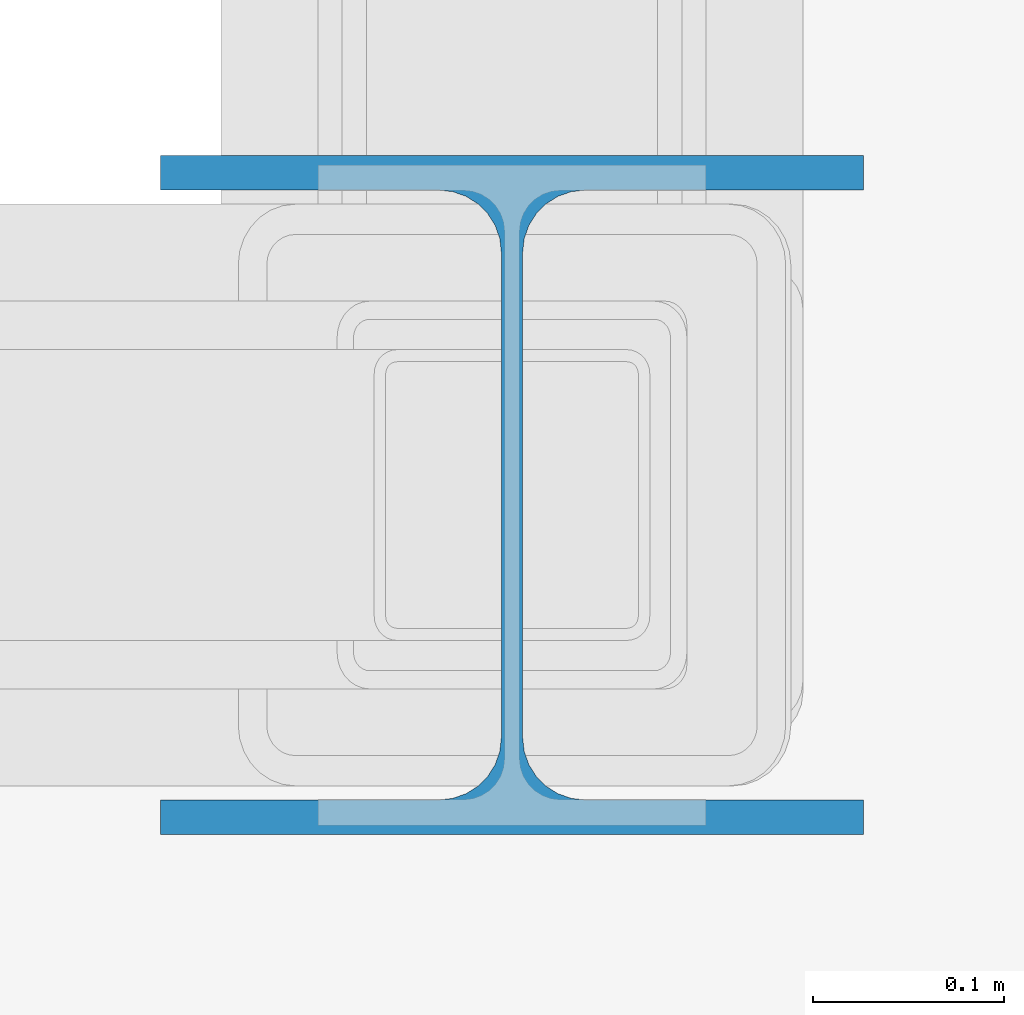
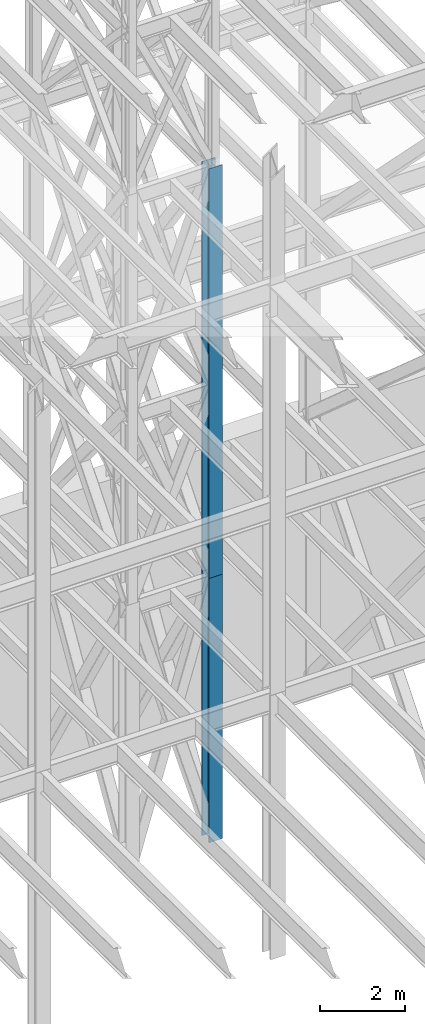
# One storey, part 105 of 150: 2 columns.
"""IFC2X3 building model written with IfcOpenShell, lengths in millimetres."""

from ifc_helpers import new_model, si_unit, frame, origin_with_axes, origin_2d_with_axis, place, context, subcontext, project, spatial, i_section, extrude, material, type_object, element, save


model = new_model("IFC2X3")

# Units and contexts
model_context = context("Model", 3, precision=1e-05, world=origin_with_axes())
body_context = subcontext(model_context, "Body", "Model", "MODEL_VIEW")
ifc_project = project(units=[si_unit("LENGTHUNIT", "METRE", prefix="MILLI"), si_unit("AREAUNIT", "SQUARE_METRE"), si_unit("VOLUMEUNIT", "CUBIC_METRE"), si_unit("MASSUNIT", "GRAM", prefix="KILO"), si_unit("TIMEUNIT", "SECOND"), si_unit("PLANEANGLEUNIT", "RADIAN"), si_unit("SOLIDANGLEUNIT", "STERADIAN"), si_unit("THERMODYNAMICTEMPERATUREUNIT", "DEGREE_CELSIUS"), si_unit("LUMINOUSINTENSITYUNIT", "LUMEN")], contexts=[model_context])

# Site, building, storey
site_placement = place(None, origin_with_axes())
site = spatial("IfcSite", under=ifc_project, at=site_placement, CompositionType="ELEMENT")
building_placement = place(site_placement, origin_with_axes())
building = spatial("IfcBuilding", under=site, at=building_placement, Name="Undefined", CompositionType="ELEMENT")
storey_placement = place(building_placement, origin_with_axes())
storey = spatial("IfcBuildingStorey", under=building, at=storey_placement, Name="Undefined", CompositionType="ELEMENT", Elevation=0.0)

# Columns
ifc_material = material(Name="STEEL/A992")
column_type = type_object("IfcColumnType", Name="W14X90", PredefinedType="NOTDEFINED")
column_1_placement = place(storey_placement, frame((76923.9, 27355.8, 23774.4), z_axis=(0.0, 0.0, 1.0), x_axis=(1.0, 0.0, 0.0)))
element("IfcColumn", 1, at=column_1_placement, inside=storey, type_object=column_type, material=ifc_material, Name="COLUMN", ObjectType="W14X90", context=body_context, shape_type="SweptSolid", body=[
    extrude(i_section(OverallWidth=368.3, OverallDepth=355.6, WebThickness=11.1125, FlangeThickness=18.034, FilletRadius=32.7659, at=origin_2d_with_axis()), frame((0.0, 0.0, 11811.0), z_axis=(0.0, 0.0, -1.0), x_axis=(-1.0, 0.0, 0.0)), (0.0, 0.0, 1.0), 11811.0),
])
column_2_placement = place(storey_placement, frame((76923.9, 27355.8, 16154.4), z_axis=(0.0, 0.0, 1.0), x_axis=(1.0, 0.0, 0.0)))
element("IfcColumn", 2, at=column_2_placement, inside=storey, type_object=column_type, material=ifc_material, Name="COLUMN", ObjectType="W14X90", context=body_context, shape_type="SweptSolid", body=[
    extrude(i_section(OverallWidth=368.3, OverallDepth=355.6, WebThickness=11.1125, FlangeThickness=18.034, FilletRadius=32.7659, at=origin_2d_with_axis()), frame((0.0, 0.0, 7620.0), z_axis=(0.0, 0.0, -1.0), x_axis=(-1.0, 0.0, 0.0)), (0.0, 0.0, 1.0), 7620.0),
])

save(model, "model.ifc")
